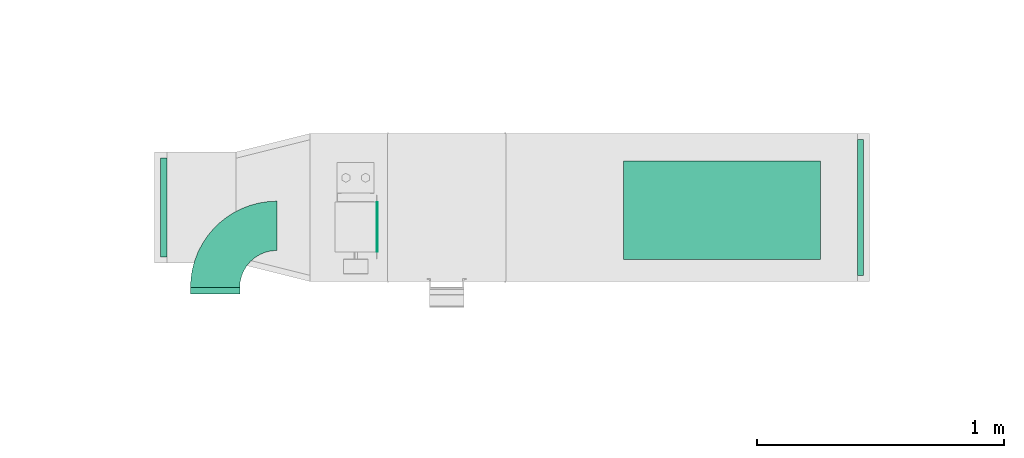
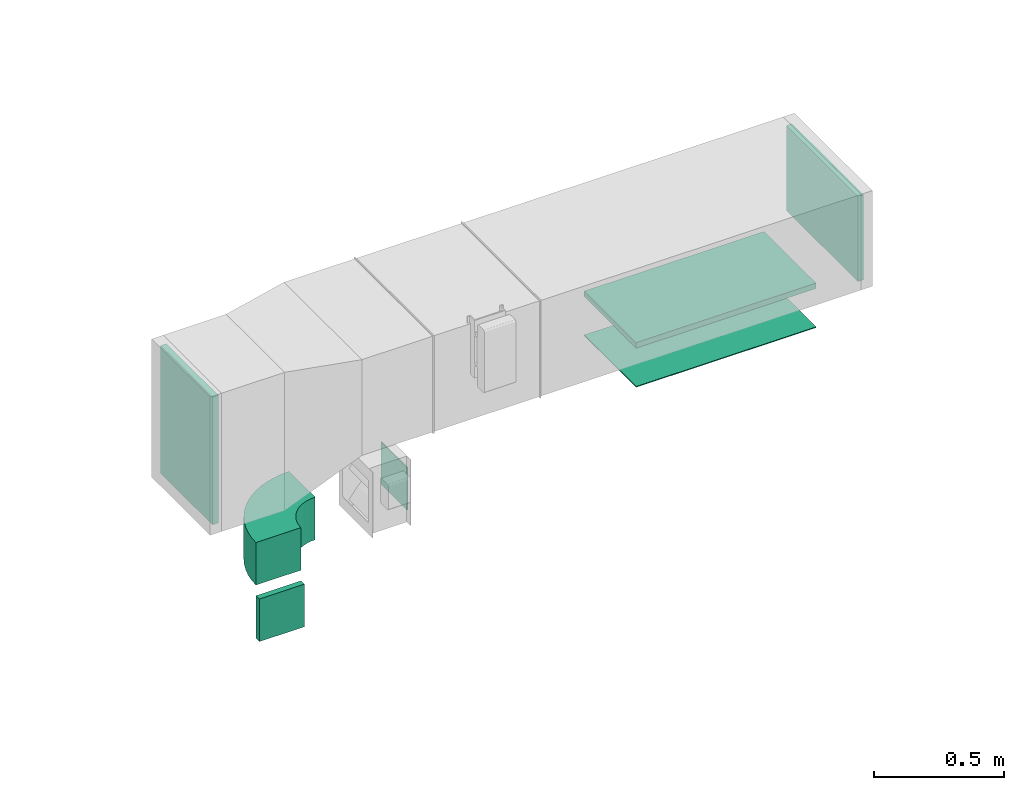
# One storey, part 5 of 10: 5 flow fittings, 2 flow terminals.
"""IFC2X3 building model written with IfcOpenShell, lengths in millimetres."""

import ifcopenshell
import ifcopenshell.guid

model = None  # the IFC model being written
_history = None  # IfcOwnerHistory: only IFC2X3 demands one
_inside = {}  # id of a spatial element -> (the spatial element, [elements in it])
_under = {}  # id of a project, library or spatial element -> (it, [spatial elements below it])
_declared = {}  # id of a project -> (the project, [libraries it declares])
_typed = {}  # id of a type object -> (the type object, [elements of that type])
_made_of = {}  # id of a material, layer set ... -> (it, [elements and type objects made of it])


def new_model(schema):
    """Start an empty IFC model of exactly this schema.

    Asked for "IFC4X3", IfcOpenShell would pick the latest addendum, in which some entities
    have other attributes; the version numbers below select the first issue.
    IFC2X3 requires an IfcOwnerHistory on every rooted entity: one is made here for all.
    """
    global model, _history
    if schema == "IFC4X3":
        model = ifcopenshell.file(schema_version=(4, 3, 0, 0))
    else:
        model = ifcopenshell.file(schema=schema)
    _inside.clear()
    _under.clear()
    _declared.clear()
    _typed.clear()
    _made_of.clear()
    _history = None
    if model.schema == "IFC2X3":
        org = make("IfcOrganization", Name="unknown")
        user = make(
            "IfcPersonAndOrganization",
            ThePerson=make("IfcPerson", FamilyName="unknown"),
            TheOrganization=org,
        )
        app = make(
            "IfcApplication",
            ApplicationDeveloper=org,
            Version="unknown",
            ApplicationFullName="unknown",
            ApplicationIdentifier="unknown",
        )
        _history = make(
            "IfcOwnerHistory",
            OwningUser=user,
            OwningApplication=app,
            ChangeAction="ADDED",
            CreationDate=0,
        )
    return model


def make(cls, **values):
    """One entity of the class cls with the attributes given. An attribute that is None is left unset."""
    return model.create_entity(
        cls, **{name: value for name, value in values.items() if value is not None}
    )


def entity(cls, *values):
    """Any entity or typed value of the class cls, its attributes in the order of the schema. None: left unset."""
    e = model.create_entity(cls)
    for i, value in enumerate(values):
        if value is not None:
            e[i] = value
    return e


def rooted(cls, **values):
    """An entity with a GlobalId (a new one), such as an element, a storey or a relation."""
    return make(cls, GlobalId=ifcopenshell.guid.new(), OwnerHistory=_history, **values)


def si_unit(unit_type, name, prefix=None):
    """IfcSIUnit, for example si_unit("LENGTHUNIT", "METRE", prefix="MILLI")."""
    return make("IfcSIUnit", UnitType=unit_type, Prefix=prefix, Name=name)


def converted_unit(unit_type, name, factor, base, dimensions=None, offset=None):
    """IfcConversionBasedUnit, such as the inch: factor (a typed value) times the base unit."""
    return make(
        "IfcConversionBasedUnit"
        if offset is None
        else "IfcConversionBasedUnitWithOffset",
        ConversionOffset=offset,
        Dimensions=None
        if dimensions is None
        else entity("IfcDimensionalExponents", *dimensions),
        UnitType=unit_type,
        Name=name,
        ConversionFactor=make(
            "IfcMeasureWithUnit", ValueComponent=factor, UnitComponent=base
        ),
    )


def derived_unit(unit_type, elements):
    """IfcDerivedUnit: a product of units, each with its exponent."""
    return make(
        "IfcDerivedUnit",
        Elements=[
            make("IfcDerivedUnitElement", Unit=unit, Exponent=power)
            for unit, power in elements
        ],
        UnitType=unit_type,
    )


def assignment(units):
    """IfcUnitAssignment: the units of a project."""
    return None if units is None else make("IfcUnitAssignment", Units=units)


def point(xyz):
    """IfcCartesianPoint."""
    return None if xyz is None else make("IfcCartesianPoint", Coordinates=xyz)


def direction(xyz):
    """IfcDirection."""
    return None if xyz is None else make("IfcDirection", DirectionRatios=xyz)


def frame(location, z_axis=None, x_axis=None):
    """IfcAxis2Placement3D, a coordinate frame: its origin and axes. An axis left out is left unset."""
    return make(
        "IfcAxis2Placement3D",
        Location=point(location),
        Axis=direction(z_axis),
        RefDirection=direction(x_axis),
    )


def frame_2d(location, x_axis=None):
    """IfcAxis2Placement2D, a coordinate frame in the plane: its origin and x axis."""
    return make(
        "IfcAxis2Placement2D", Location=point(location), RefDirection=direction(x_axis)
    )


def origin():
    """The frame at (0, 0, 0) with its axes left unset."""
    return frame((0.0, 0.0, 0.0))


def origin_2d_with_axis():
    """The frame at (0, 0) in the plane with the x axis (1, 0) written out."""
    return frame_2d((0.0, 0.0), x_axis=(1.0, 0.0))


def place(relative_to, where):
    """IfcLocalPlacement: puts the frame where relative to a parent placement (None: the world)."""
    return make(
        "IfcLocalPlacement", PlacementRelTo=relative_to, RelativePlacement=where
    )


def context(
    kind, dimensions, precision=None, world=None, true_north=None, identifier=None
):
    """IfcGeometricRepresentationContext, for example the 3D "Model" context."""
    return make(
        "IfcGeometricRepresentationContext",
        ContextIdentifier=identifier,
        ContextType=kind,
        CoordinateSpaceDimension=dimensions,
        Precision=precision,
        WorldCoordinateSystem=world,
        TrueNorth=true_north,
    )


def subcontext(parent, identifier, kind, view, scale=None):
    """IfcGeometricRepresentationSubContext, for example "Body" below "Model"."""
    return make(
        "IfcGeometricRepresentationSubContext",
        ContextIdentifier=identifier,
        ContextType=kind,
        ParentContext=parent,
        TargetScale=scale,
        TargetView=view,
    )


def project(units=None, contexts=None):
    """IfcProject with its units and contexts."""
    return rooted(
        "IfcProject",
        Name="project",
        RepresentationContexts=contexts,
        UnitsInContext=assignment(units),
    )


def spatial(cls, under=None, at=None, **own):
    """A site, building, storey or space (cls), placed at a placement, below another one or the project."""
    s = rooted(cls, ObjectPlacement=at, **own)
    if under is not None:
        _under.setdefault(under.id(), (under, []))[1].append(s)
    return s


def polyline(points):
    """IfcPolyline through the points."""
    return make("IfcPolyline", Points=[point(p) for p in points])


def circle_curve(where, radius):
    """IfcCircle in the frame where."""
    return make("IfcCircle", Position=where, Radius=radius)


def parameter(value):
    """IfcParameterValue: where a trimmed curve begins or ends, as a parameter of its basis curve."""
    return model.create_entity("IfcParameterValue", value)


def trimmed(basis, trim1, trim2, sense, master):
    """IfcTrimmedCurve: the piece of a basis curve between two trims."""
    return make(
        "IfcTrimmedCurve",
        BasisCurve=basis,
        Trim1=trim1,
        Trim2=trim2,
        SenseAgreement=sense,
        MasterRepresentation=master,
    )


def segment(curve, same_sense, transition):
    """IfcCompositeCurveSegment."""
    return make(
        "IfcCompositeCurveSegment",
        Transition=transition,
        SameSense=same_sense,
        ParentCurve=curve,
    )


def composite_curve(segments, self_intersect=None):
    """IfcCompositeCurve: segments joined end to end."""
    return make("IfcCompositeCurve", Segments=segments, SelfIntersect=self_intersect)


def profile(cls, at=None, kind="AREA", **sizes):
    """A parametric profile (cls). Its sizes go by their IFC names, for example OverallWidth=200.0."""
    return make(cls, ProfileType=kind, Position=at, **sizes)


def rectangle(**sizes):
    """IfcRectangleProfileDef."""
    return profile("IfcRectangleProfileDef", **sizes)


def outline(outer, holes=None, kind="AREA"):
    """IfcArbitraryClosedProfileDef: a profile drawn as a closed curve; with holes, ...WithVoids."""
    if holes is None:
        return make("IfcArbitraryClosedProfileDef", ProfileType=kind, OuterCurve=outer)
    return make(
        "IfcArbitraryProfileDefWithVoids",
        ProfileType=kind,
        OuterCurve=outer,
        InnerCurves=holes,
    )


def extrude(swept, where, along, depth):
    """IfcExtrudedAreaSolid: the profile swept, set in the frame where, extruded along a direction by depth."""
    return make(
        "IfcExtrudedAreaSolid",
        SweptArea=swept,
        Position=where,
        ExtrudedDirection=direction(along),
        Depth=depth,
    )


def shape(context_of_items, identifier, shape_type, items):
    """IfcShapeRepresentation: the items that make up one representation, for example the "Body"."""
    return make(
        "IfcShapeRepresentation",
        ContextOfItems=context_of_items,
        RepresentationIdentifier=identifier,
        RepresentationType=shape_type,
        Items=items,
    )


def source(mapping_origin, context_of_items, identifier, shape_type, items):
    """IfcRepresentationMap: a shape defined once, which mapped items show again and again."""
    return make(
        "IfcRepresentationMap",
        MappingOrigin=mapping_origin,
        MappedRepresentation=shape(context_of_items, identifier, shape_type, items),
    )


def transform(
    local_origin,
    x_axis=None,
    y_axis=None,
    z_axis=None,
    scale=None,
    scale2=None,
    scale3=None,
    uniform=True,
):
    """IfcCartesianTransformationOperator3D, or its non-uniform kind. x_axis, y_axis, z_axis: its Axis1, 2, 3."""
    if uniform:
        return make(
            "IfcCartesianTransformationOperator3D",
            Axis1=direction(x_axis),
            Axis2=direction(y_axis),
            LocalOrigin=point(local_origin),
            Scale=scale,
            Axis3=direction(z_axis),
        )
    return make(
        "IfcCartesianTransformationOperator3DnonUniform",
        Axis1=direction(x_axis),
        Axis2=direction(y_axis),
        LocalOrigin=point(local_origin),
        Scale=scale,
        Axis3=direction(z_axis),
        Scale2=scale2,
        Scale3=scale3,
    )


def mapped(mapping_source, mapping_target):
    """IfcMappedItem: shows the shape of a source again, moved by a transform."""
    return make(
        "IfcMappedItem", MappingSource=mapping_source, MappingTarget=mapping_target
    )


def material(Name=None, Category=None):
    """IfcMaterial."""
    return make("IfcMaterial", Name=Name, Category=Category)


def made_of(thing, what):
    """Note that an element or type object is made of a material, layer set ...; save() writes the relation."""
    if what is not None:
        _made_of.setdefault(what.id(), (what, []))[1].append(thing)
    return thing


def type_object(cls, material=None, **own):
    """A type object (cls), such as IfcWallType, which elements share."""
    return made_of(rooted(cls, **own), material)


def type_shapes(of_type, sources):
    """Give a type object the sources (RepresentationMaps) that its elements show as mapped items."""
    of_type.RepresentationMaps = sources


def element(
    cls,
    number,
    at=None,
    inside=None,
    cuts=None,
    type_object=None,
    material=None,
    context=None,
    identifier="Body",
    shape_type=None,
    held_by="IfcProductDefinitionShape",
    body=None,
    shapes=None,
    **own,
):
    """One element of the class cls, such as IfcWall. Its Tag is "e" and its number.

    at: its placement. inside: the storey or other place that contains it. cuts: it is an
    opening in that element (IfcRelVoidsElement). A single representation is given by context,
    identifier, shape_type and body (its items); several are given by shapes. held_by: the class
    of the entity that holds the representations. save() writes the other relations.
    """
    e = rooted(cls, Tag="e%d" % number, ObjectPlacement=at, **own)
    if body is not None:
        shapes = [shape(context, identifier, shape_type, body)]
    if shapes is not None:
        e.Representation = make(held_by, Representations=shapes)
    if inside is not None:
        _inside.setdefault(inside.id(), (inside, []))[1].append(e)
    if cuts is not None:
        rooted(
            "IfcRelVoidsElement", RelatingBuildingElement=cuts, RelatedOpeningElement=e
        )
    if type_object is not None:
        _typed.setdefault(type_object.id(), (type_object, []))[1].append(e)
    return made_of(e, material)


def aggregate(whole, parts):
    """IfcRelAggregates: a whole, such as a stair, and the parts it consists of."""
    return rooted("IfcRelAggregates", RelatingObject=whole, RelatedObjects=parts)


def save(model, path):
    """Write the relations noted so far, then the file.

    IfcRelAggregates (storeys below a building ...), IfcRelContainedInSpatialStructure (elements
    in a storey), IfcRelDefinesByType, IfcRelAssociatesMaterial and IfcRelDeclares: one each for
    every whole, place, type object, material and project.
    """
    for whole, parts in _under.values():
        aggregate(whole, parts)
    for where, things in _inside.values():
        rooted(
            "IfcRelContainedInSpatialStructure",
            RelatedElements=things,
            RelatingStructure=where,
        )
    for kind, things in _typed.values():
        rooted("IfcRelDefinesByType", RelatedObjects=things, RelatingType=kind)
    for what, things in _made_of.values():
        rooted("IfcRelAssociatesMaterial", RelatedObjects=things, RelatingMaterial=what)
    for by, libraries in _declared.values():
        rooted("IfcRelDeclares", RelatingContext=by, RelatedDefinitions=libraries)
    model.write(path)


model = new_model("IFC2X3")

# Units and contexts
model_context = context("Model", 3, precision=0.01, world=origin(), true_north=direction((6.12303176911189e-17, 1.0)))
body_context = subcontext(model_context, "Body", "Model", "MODEL_VIEW")
ifc_project = project(units=[si_unit("LENGTHUNIT", "METRE", prefix="MILLI"), si_unit("AREAUNIT", "SQUARE_METRE"), si_unit("VOLUMEUNIT", "CUBIC_METRE"), converted_unit("PLANEANGLEUNIT", "DEGREE", entity("IfcRatioMeasure", 0.0174532925199433), si_unit("PLANEANGLEUNIT", "RADIAN"), dimensions=[0, 0, 0, 0, 0, 0, 0]), si_unit("MASSUNIT", "GRAM", prefix="KILO"), derived_unit("MASSDENSITYUNIT", [(si_unit("MASSUNIT", "GRAM", prefix="KILO"), 1), (si_unit("LENGTHUNIT", "METRE"), -3)]), derived_unit("MOMENTOFINERTIAUNIT", [(si_unit("LENGTHUNIT", "METRE"), 4)]), si_unit("TIMEUNIT", "SECOND"), si_unit("FREQUENCYUNIT", "HERTZ"), si_unit("THERMODYNAMICTEMPERATUREUNIT", "DEGREE_CELSIUS"), derived_unit("THERMALTRANSMITTANCEUNIT", [(si_unit("MASSUNIT", "GRAM", prefix="KILO"), 1), (si_unit("THERMODYNAMICTEMPERATUREUNIT", "KELVIN"), -1), (si_unit("TIMEUNIT", "SECOND"), -3)]), derived_unit("VOLUMETRICFLOWRATEUNIT", [(si_unit("LENGTHUNIT", "METRE"), 3), (si_unit("TIMEUNIT", "SECOND"), -1)]), derived_unit("MASSFLOWRATEUNIT", [(si_unit("MASSUNIT", "GRAM", prefix="KILO"), 1), (si_unit("TIMEUNIT", "SECOND"), -1)]), derived_unit("ROTATIONALFREQUENCYUNIT", [(si_unit("TIMEUNIT", "SECOND"), -1)]), si_unit("ELECTRICCURRENTUNIT", "AMPERE"), si_unit("ELECTRICVOLTAGEUNIT", "VOLT"), si_unit("POWERUNIT", "WATT"), si_unit("FORCEUNIT", "NEWTON", prefix="KILO"), si_unit("ILLUMINANCEUNIT", "LUX"), si_unit("LUMINOUSFLUXUNIT", "LUMEN"), si_unit("LUMINOUSINTENSITYUNIT", "CANDELA"), derived_unit("USERDEFINED", [(si_unit("MASSUNIT", "GRAM", prefix="KILO"), -1), (si_unit("LENGTHUNIT", "METRE"), -2), (si_unit("TIMEUNIT", "SECOND"), 3), (si_unit("LUMINOUSFLUXUNIT", "LUMEN"), 1)]), derived_unit("LINEARVELOCITYUNIT", [(si_unit("LENGTHUNIT", "METRE"), 1), (si_unit("TIMEUNIT", "SECOND"), -1)]), si_unit("PRESSUREUNIT", "PASCAL"), derived_unit("USERDEFINED", [(si_unit("LENGTHUNIT", "METRE"), -2), (si_unit("MASSUNIT", "GRAM", prefix="KILO"), 1), (si_unit("TIMEUNIT", "SECOND"), -2)]), derived_unit("LINEARFORCEUNIT", [(si_unit("MASSUNIT", "GRAM", prefix="KILO"), 1), (si_unit("LENGTHUNIT", "METRE"), 1), (si_unit("TIMEUNIT", "SECOND"), -2), (si_unit("LENGTHUNIT", "METRE"), -1)]), derived_unit("PLANARFORCEUNIT", [(si_unit("MASSUNIT", "GRAM", prefix="KILO"), 1), (si_unit("LENGTHUNIT", "METRE"), 1), (si_unit("TIMEUNIT", "SECOND"), -2), (si_unit("LENGTHUNIT", "METRE"), -2)])], contexts=[model_context])

# Site, building, storey
site_placement = place(None, frame((0.0, -0.00077364408347762, 0.0)))
site = spatial("IfcSite", under=ifc_project, at=site_placement, CompositionType="ELEMENT")
building_placement = place(site_placement, origin())
building = spatial("IfcBuilding", under=site, at=building_placement, CompositionType="ELEMENT")
storey_placement = place(building_placement, frame((0.0, 0.0, 8100.0)))
storey = spatial("IfcBuildingStorey", under=building, at=storey_placement, CompositionType="ELEMENT", Elevation=8100.0)

# Flow fittings
ifc_material_1 = material()
duct_fitting_type_1 = type_object("IfcDuctFittingType", PredefinedType="NOTDEFINED", material=ifc_material_1)
shared_shape_1 = source(origin(), body_context, "Body", "SweptSolid", [
    extrude(rectangle(XDim=800.0, YDim=26.096, at=frame_2d((-5.6843418860808e-14, 0.0), x_axis=(1.0, 0.0))), frame((6.95199999999999, 0.0, -200.0), z_axis=(0.0, 0.0, 1.0), x_axis=(0.0, -1.0, 0.0)), (0.0, 0.0, 1.0), 400.0),
])
type_shapes(duct_fitting_type_1, [shared_shape_1])
flow_fitting_1_placement = place(storey_placement, frame((12300.1283257901, 14784.0835453812, 3000.0), z_axis=(0.0, 1.0, 0.0), x_axis=(0.0, 0.0, -1.0)))
element("IfcFlowFitting", 1, at=flow_fitting_1_placement, inside=storey, type_object=duct_fitting_type_1, material=ifc_material_1, context=body_context, shape_type="MappedRepresentation", body=[
    mapped(shared_shape_1, transform((0.0, 0.0, 0.0), scale=1.0)),
])
duct_fitting_type_2 = type_object("IfcDuctFittingType", PredefinedType="NOTDEFINED", material=ifc_material_1)
shared_shape_2 = source(origin(), body_context, "Body", "SweptSolid", [
    extrude(rectangle(XDim=24.9999999999999, YDim=550.0, at=frame_2d((-2.28261853862932e-13, 0.0), x_axis=(1.0, 0.0))), frame((12.500000000006, 0.0, -200.0)), (0.0, 0.0, 1.0), 400.0),
])
type_shapes(duct_fitting_type_2, [shared_shape_2])
flow_fitting_2_placement = place(storey_placement, frame((12848.4871552699, 14795.0835453812, 3200.0)))
element("IfcFlowFitting", 2, at=flow_fitting_2_placement, inside=storey, type_object=duct_fitting_type_2, material=ifc_material_1, context=body_context, shape_type="MappedRepresentation", body=[
    mapped(shared_shape_2, transform((0.0, 0.0, 0.0), scale=1.0)),
])
duct_fitting_type_3 = type_object("IfcDuctFittingType", PredefinedType="NOTDEFINED", material=ifc_material_1)
shared_shape_3 = source(origin(), body_context, "Body", "SweptSolid", [
    extrude(rectangle(XDim=600.0, YDim=26.096, at=origin_2d_with_axis()), frame((6.95199999999999, 0.0, -200.0), z_axis=(0.0, 0.0, 1.0), x_axis=(0.0, -1.0, 0.0)), (0.0, 0.0, 1.0), 400.0),
])
type_shapes(duct_fitting_type_3, [shared_shape_3])
flow_fitting_3_placement = place(storey_placement, frame((10029.7340134019, 14795.0835453813, 3100.0), z_axis=(0.0, -1.0, 0.0), x_axis=(1.0, 0.0, 0.0)))
element("IfcFlowFitting", 3, at=flow_fitting_3_placement, inside=storey, type_object=duct_fitting_type_3, material=ifc_material_1, context=body_context, shape_type="MappedRepresentation", body=[
    mapped(shared_shape_3, transform((0.0, 0.0, 0.0), scale=1.0)),
])

# Flow terminal
ifc_material_2 = material()
air_terminal_type_1 = type_object("IfcAirTerminalType", PredefinedType="NOTDEFINED", material=ifc_material_2)
shared_shape_4 = source(origin(), body_context, "Body", "SweptSolid", [
    extrude(rectangle(XDim=4.0, YDim=799.999999999999, at=origin_2d_with_axis()), frame((0.0, -2.0, -200.0), z_axis=(0.0, 0.0, 1.0), x_axis=(0.0, 1.0, 0.0)), (0.0, 0.0, 1.0), 400.000000000005),
])
type_shapes(air_terminal_type_1, [shared_shape_4])
flow_terminal_1_placement = place(storey_placement, frame((12300.1283257901, 14784.0835453812, 2800.0), z_axis=(0.0, 1.0, 0.0), x_axis=(-1.0, 0.0, 0.0)))
element("IfcFlowTerminal", 4, at=flow_terminal_1_placement, inside=storey, type_object=air_terminal_type_1, material=ifc_material_2, context=body_context, shape_type="MappedRepresentation", body=[
    mapped(shared_shape_4, transform((0.0, 0.0, 0.0), scale=1.0)),
])

# Flow fitting
duct_fitting_type_4 = type_object("IfcDuctFittingType", PredefinedType="NOTDEFINED", material=ifc_material_1)
shared_shape_5 = source(origin(), body_context, "Body", "SweptSolid", [
    extrude(outline(composite_curve([segment(polyline([(-225.0, -125.0), (-25.0, -125.0)]), True, "CONTINUOUS"), segment(trimmed(circle_curve(frame_2d((125.0, -125.0), x_axis=(0.0, 1.0)), 150.0), [parameter(0.0)], [parameter(90.0000000000001)], True, "PARAMETER"), False, "CONTINUOUS"), segment(polyline([(125.0, 25.0), (125.0, 225.0)]), True, "CONTINUOUS"), segment(trimmed(circle_curve(frame_2d((125.0, -125.0), x_axis=(0.0, 1.0)), 350.0), [parameter(0.0)], [parameter(90.0000000000001)], True, "PARAMETER"), True, "CONTINUOUS")], self_intersect=False)), frame((-125.0, 125.0, -100.0), z_axis=(0.0, 0.0, 1.0), x_axis=(-1.0, 0.0, 0.0)), (0.0, 0.0, 1.0), 200.0),
])
type_shapes(duct_fitting_type_4, [shared_shape_5])
flow_fitting_4_placement = place(storey_placement, frame((10244.7174683872, 14720.8402530396, 2650.0), z_axis=(0.0, 0.0, 1.0), x_axis=(-1.0, 0.0, 0.0)))
element("IfcFlowFitting", 5, at=flow_fitting_4_placement, inside=storey, type_object=duct_fitting_type_4, material=ifc_material_1, context=body_context, shape_type="MappedRepresentation", body=[
    mapped(shared_shape_5, transform((0.0, 0.0, 0.0), scale=1.0)),
])

# Flow terminal
air_terminal_type_2 = type_object("IfcAirTerminalType", PredefinedType="NOTDEFINED", material=ifc_material_2)
shared_shape_6 = source(origin(), body_context, "Body", "SweptSolid", [
    extrude(rectangle(XDim=4.0, YDim=199.999999999999, at=origin_2d_with_axis()), frame((0.0, -2.0, -100.0), z_axis=(0.0, 0.0, 1.0), x_axis=(0.0, 1.0, 0.0)), (0.0, 0.0, 1.0), 200.000000000005),
])
type_shapes(air_terminal_type_2, [shared_shape_6])
flow_terminal_2_placement = place(storey_placement, frame((10899.8744854646, 14716.4821803333, 2650.0), z_axis=(0.0, 0.0, 1.0), x_axis=(0.0, 1.0, 0.0)))
element("IfcFlowTerminal", 6, at=flow_terminal_2_placement, inside=storey, type_object=air_terminal_type_2, material=ifc_material_2, context=body_context, shape_type="MappedRepresentation", body=[
    mapped(shared_shape_6, transform((0.0, 0.0, 0.0), scale=1.0)),
])

# Flow fitting
duct_fitting_type_5 = type_object("IfcDuctFittingType", PredefinedType="NOTDEFINED", material=ifc_material_1)
shared_shape_7 = source(origin(), body_context, "Body", "SweptSolid", [
    extrude(rectangle(XDim=200.0, YDim=26.096, at=frame_2d((-1.4210854715202e-14, 0.0), x_axis=(1.0, 0.0))), frame((6.95199999999999, 0.0, -100.0), z_axis=(0.0, 0.0, 1.0), x_axis=(0.0, -1.0, 0.0)), (0.0, 0.0, 1.0), 200.0),
])
type_shapes(duct_fitting_type_5, [shared_shape_7])
flow_fitting_5_placement = place(storey_placement, frame((10244.7174683872, 14450.8402530397, 2400.0), z_axis=(1.0, 0.0, 0.0), x_axis=(0.0, 1.0, 0.0)))
element("IfcFlowFitting", 7, at=flow_fitting_5_placement, inside=storey, type_object=duct_fitting_type_5, material=ifc_material_1, context=body_context, shape_type="MappedRepresentation", body=[
    mapped(shared_shape_7, transform((0.0, 0.0, 0.0), scale=1.0)),
])

save(model, "model.ifc")
